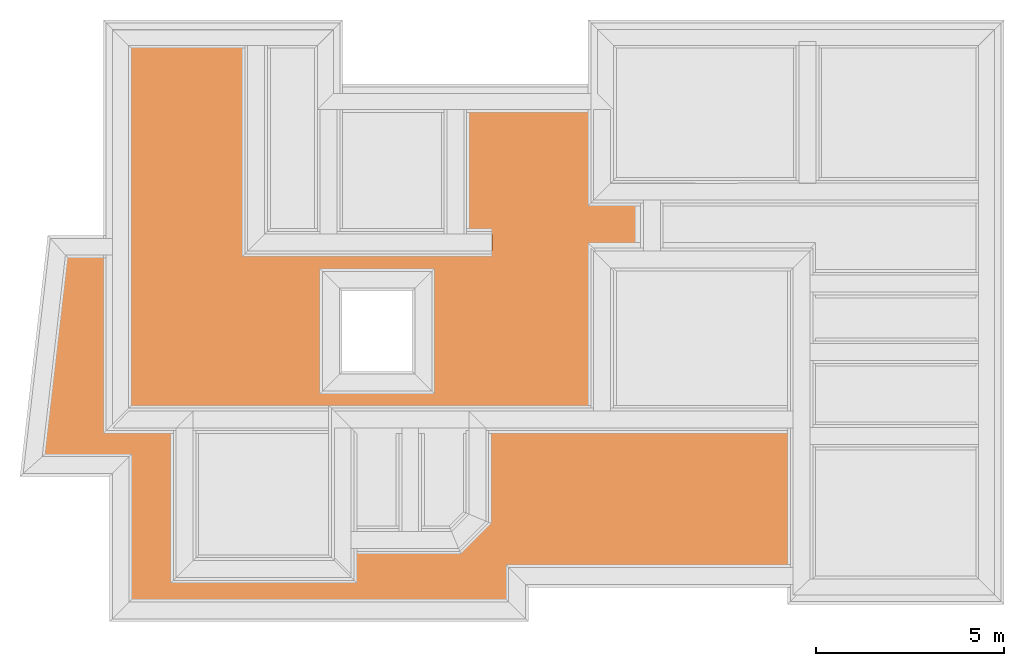
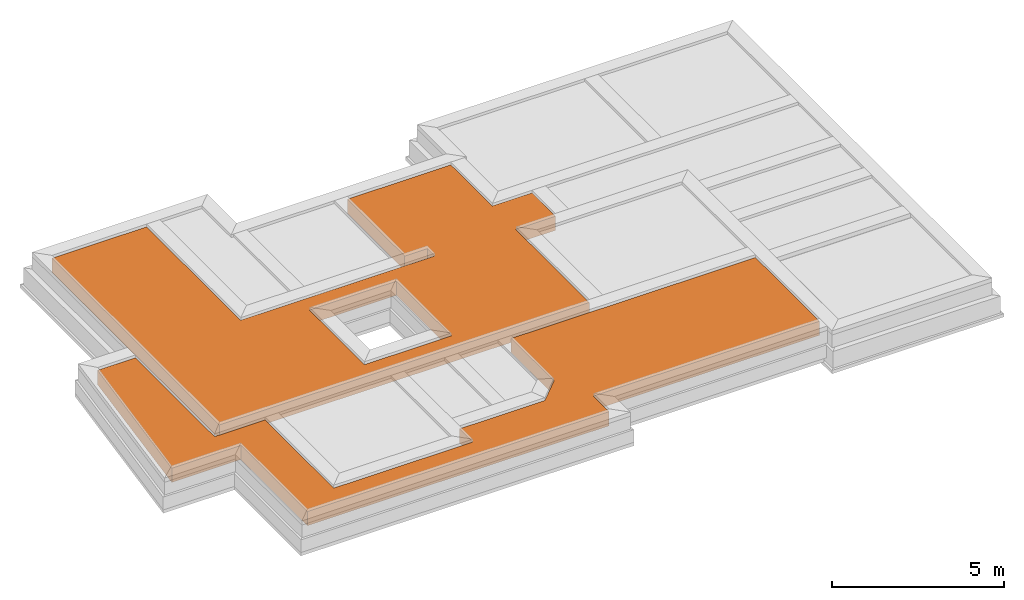
# One storey, part 6 of 6: 2 earthworks fills.
"""IFC4X3_ADD2 building model written with IfcOpenShell, lengths in metres."""

from ifc_helpers import new_model, entity, si_unit, converted_unit, frame, origin_with_axes, origin_2d_with_axis, place, context, subcontext, project, spatial, polygons, element, save


model = new_model("IFC4X3_ADD2")

# Units and contexts
model_context = context("Model", 3, precision=1e-05, world=origin_with_axes())
plan_context = context("Plan", 2, precision=1e-05, world=origin_2d_with_axis())
body_context = subcontext(model_context, "Body", "Model", "MODEL_VIEW")
ifc_project = project(units=[si_unit("VOLUMEUNIT", "CUBIC_METRE"), si_unit("LENGTHUNIT", "METRE"), converted_unit("PLANEANGLEUNIT", "degree", entity("IfcReal", 0.0174532925199433), si_unit("PLANEANGLEUNIT", "RADIAN"), dimensions=[0, 0, 0, 0, 0, 0, 0]), si_unit("AREAUNIT", "SQUARE_METRE")], contexts=[model_context, plan_context])

# Site, building, storey
site_placement = place(None, origin_with_axes())
site = spatial("IfcSite", under=ifc_project, at=site_placement)
building_placement = place(site_placement, origin_with_axes())
building = spatial("IfcBuilding", under=site, at=building_placement, Name="Building")
storey_placement = place(building_placement, frame((0.0, 0.0, -0.870000004768372), z_axis=(0.0, 0.0, 1.0), x_axis=(1.0, 0.0, 0.0)))
storey = spatial("IfcBuildingStorey", under=building, at=storey_placement, Name="Footing")

# Earthworks fills
earthworks_fill_1_placement = place(storey_placement, frame((16.1664161682129, 18.8340358734131, 0.719999670982361), z_axis=(0.0, 0.0, 1.0), x_axis=(1.0, 0.0, 0.0)))
element("IfcEarthworksFill", 1, at=earthworks_fill_1_placement, inside=storey, Name="Slab", PredefinedType="BACKFILL", context=body_context, shape_type="Tessellation", body=[
    polygons([(-1.01973915100098, -5.49912452697754, 0.500000357627869), (-1.01973915100098, -5.49912452697754, 0.0), (-1.01967811584473, -3.01801776885986, 0.0), (-1.01967811584473, -3.01801776885986, 0.500000357627869), (7.15860080718994, -3.01801776885986, 0.0), (7.15860080718994, -3.01801776885986, 0.500000357627869), (7.15860080718994, -6.73469066619873, 0.0), (7.15860080718994, -6.73469066619873, 0.500000357627869), (-0.412372142076492, -6.73469066619873, 0.0), (-0.412372142076492, -6.73469066619873, 0.500000357627869), (-0.412372142076492, -7.64789867401123, 0.0), (-0.412372142076492, -7.64789867401123, 0.500000357627869), (-10.5136985778809, -7.64789867401123, 0.0), (-10.5136985778809, -7.64789867401123, 0.500000357627869), (-10.5136985778809, -3.78365659713745, 0.0), (-10.5136985778809, -3.78365659713745, 0.500000357627869), (-12.8304462432861, -3.78365755081177, 0.0), (-12.8304462432861, -3.78365755081177, 0.500000357627869), (-12.2199640274048, 1.5894513130188, 0.0), (-12.2199640274048, 1.5894513130188, 0.500000357627869), (-10.9523773193359, 1.57944917678833, 0.0), (-10.9523773193359, 1.57944917678833, 0.500000357627869), (-10.9523773193359, -3.01801633834839, 0.0), (-10.9523773193359, -3.01801633834839, 0.500000357627869), (-9.26281929016113, -3.01801633834839, 0.0), (-9.26281929016113, -3.01801633834839, 0.500000357627869), (-9.26281929016113, -6.99801397323608, 0.0), (-9.26281929016113, -6.99801397323608, 0.500000357627869), (-4.60341644287109, -6.99801397323608, 0.0), (-4.60341644287109, -6.99801397323608, 0.500000357627869), (-4.60341644287109, -6.22681427001953, 0.0), (-4.60341644287109, -6.22681427001953, 0.500000357627869), (-1.74742984771729, -6.22681331634521, 0.0), (-1.74742984771729, -6.22681331634521, 0.500000357627869)], [[[9, 10, 8, 7]], [[16, 15, 17, 18]], [[29, 30, 28, 27]], [[5, 6, 4, 3]], [[14, 13, 15, 16]], [[7, 8, 6, 5]], [[21, 22, 20, 19]], [[11, 12, 10, 9]], [[24, 26, 28, 30, 32, 34, 1, 4, 6, 8, 10, 12, 14, 16, 18, 20, 22]], [[26, 24, 23, 25]], [[13, 14, 12, 11]], [[26, 25, 27, 28]], [[18, 17, 19, 20]], [[33, 34, 32, 31]], [[23, 21, 19, 17, 15, 13, 11, 9, 7, 5, 3, 2, 33, 31, 29, 27, 25]], [[3, 4, 1, 2]], [[31, 32, 30, 29]], [[23, 24, 22, 21]], [[2, 1, 34, 33]]]),
])
earthworks_fill_2_placement = place(storey_placement, frame((5.63903617858887, 25.9879016876221, 0.719999670982361), z_axis=(0.0, 0.0, 1.0), x_axis=(1.0, 0.0, 0.0)))
element("IfcEarthworksFill", 2, at=earthworks_fill_2_placement, inside=storey, Name="Slab", PredefinedType="BACKFILL", context=body_context, shape_type="Tessellation", body=[
    polygons([(0.0, 0.0, 0.500000357627869), (3.16919136047363, 0.0, 0.500000357627869), (3.16919136047363, -5.45359992980957, 0.500000357627869), (3.16919136047363, -5.45359992980957, 0.0), (3.16919136047363, 0.0, 0.0), (0.0, 0.0, 0.0), (12.3776264190674, -5.46495246887207, 0.500000357627869), (12.3776874542236, -4.10002326965332, 0.500000357627869), (13.7125873565674, -5.46495246887207, 0.500000357627869), (12.3776264190674, -5.46495246887207, 0.0), (13.7125873565674, -5.46495246887207, 0.0), (12.3776874542236, -4.10002326965332, 0.0), (13.7125873565674, -4.10002326965332, 0.500000357627869), (13.7125873565674, -4.10002326965332, 0.0), (8.91119575500488, -1.69798469543457, 0.500000357627869), (9.67120552062988, -5.02397346496582, 0.500000357627869), (8.91119575500488, -5.02397346496582, 0.500000357627869), (8.91119575500488, -5.02397346496582, 0.0), (8.91119575500488, -1.69798469543457, 0.0), (9.67120552062988, -5.02397346496582, 0.0), (12.3776874542236, -1.69798469543457, 0.500000357627869), (12.3776874542236, -1.69798469543457, 0.0), (9.67120552062988, -5.45359992980957, 0.500000357627869), (5.1567063331604, -6.00351285934448, 0.500000357627869), (9.67120552062988, -5.45359992980957, 0.0), (5.1567063331604, -6.00351285934448, 0.0), (12.3776264190674, -9.73179817199707, 0.500000357627869), (12.3776264190674, -9.73179817199707, 0.0), (-0.0100078582763672, -9.7318000793457, 0.500000357627869), (5.15664529800415, -9.19188499450684, 0.500000357627869), (5.15664529800415, -9.19188499450684, 0.0), (-0.0100078582763672, -9.7318000793457, 0.0), (8.06992435455322, -6.00351285934448, 0.500000357627869), (8.06992435455322, -9.19188499450684, 0.500000357627869), (8.06992435455322, -6.00351285934448, 0.0), (8.06992435455322, -9.19188499450684, 0.0)], [[[17, 18, 19, 15]], [[21, 22, 12, 8]], [[33, 35, 26, 24]], [[13, 14, 11, 9]], [[9, 11, 10, 7]], [[10, 11, 14, 12, 22, 19, 18, 20, 25, 35, 36, 31, 28]], [[3, 4, 25, 23]], [[34, 36, 35, 33]], [[8, 12, 14, 13]], [[2, 5, 4, 3]], [[16, 20, 18, 17]], [[29, 32, 6, 1]], [[7, 10, 28, 27]], [[15, 19, 22, 21]], [[23, 16, 17, 15, 21, 8, 13, 9, 7, 27, 29, 30, 34, 33]], [[1, 6, 5, 2]], [[26, 35, 25, 4, 5, 6, 32, 28, 31]], [[30, 31, 36, 34]], [[23, 25, 20, 16]], [[23, 33, 24, 30, 29, 1, 2, 3]], [[27, 28, 32, 29]], [[24, 26, 31, 30]]]),
])

save(model, "model.ifc")
